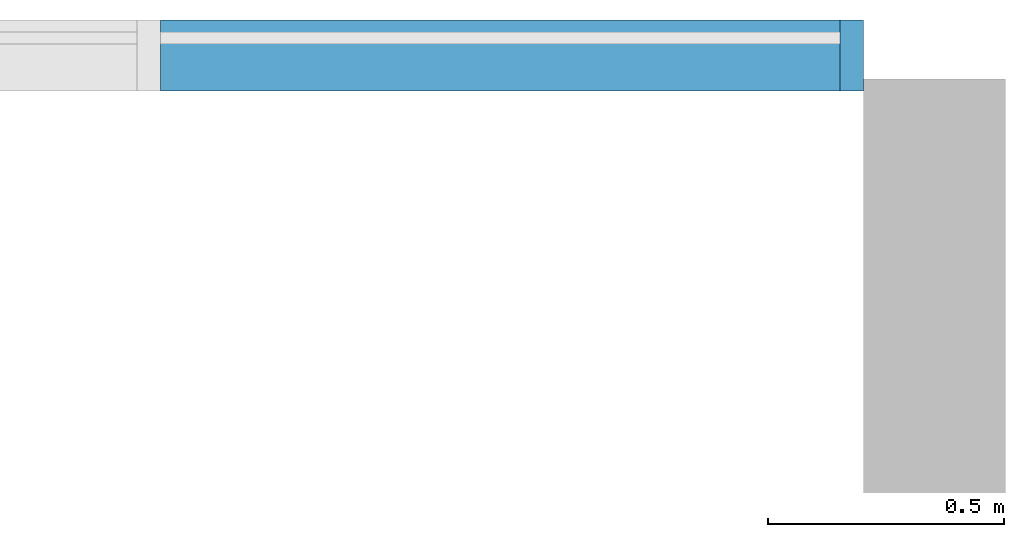
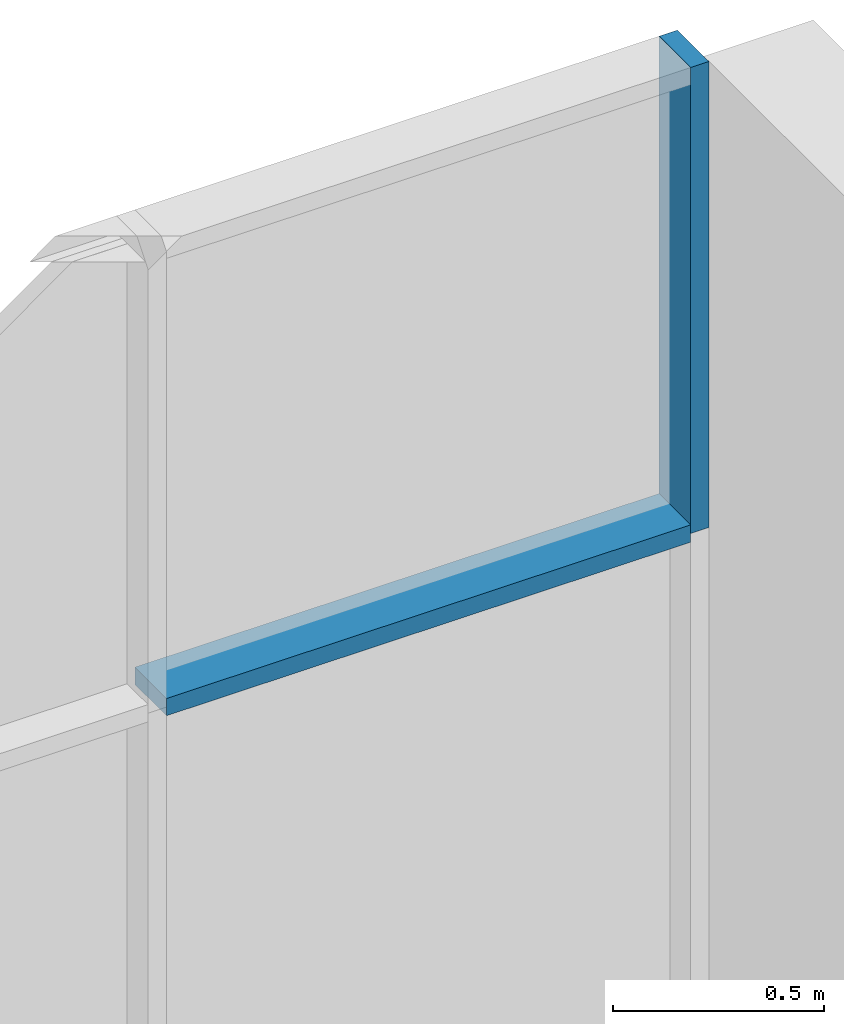
# One storey, part 5 of 13: 2 members, 1 element without a shape of its own.
"""IFC2X3 building model written with IfcOpenShell, lengths in millimetres."""

import ifcopenshell
import ifcopenshell.guid

model = None  # the IFC model being written
_history = None  # IfcOwnerHistory: only IFC2X3 demands one
_inside = {}  # id of a spatial element -> (the spatial element, [elements in it])
_under = {}  # id of a project, library or spatial element -> (it, [spatial elements below it])
_declared = {}  # id of a project -> (the project, [libraries it declares])
_typed = {}  # id of a type object -> (the type object, [elements of that type])
_made_of = {}  # id of a material, layer set ... -> (it, [elements and type objects made of it])


def new_model(schema):
    """Start an empty IFC model of exactly this schema.

    Asked for "IFC4X3", IfcOpenShell would pick the latest addendum, in which some entities
    have other attributes; the version numbers below select the first issue.
    IFC2X3 requires an IfcOwnerHistory on every rooted entity: one is made here for all.
    """
    global model, _history
    if schema == "IFC4X3":
        model = ifcopenshell.file(schema_version=(4, 3, 0, 0))
    else:
        model = ifcopenshell.file(schema=schema)
    _inside.clear()
    _under.clear()
    _declared.clear()
    _typed.clear()
    _made_of.clear()
    _history = None
    if model.schema == "IFC2X3":
        org = make("IfcOrganization", Name="unknown")
        user = make(
            "IfcPersonAndOrganization",
            ThePerson=make("IfcPerson", FamilyName="unknown"),
            TheOrganization=org,
        )
        app = make(
            "IfcApplication",
            ApplicationDeveloper=org,
            Version="unknown",
            ApplicationFullName="unknown",
            ApplicationIdentifier="unknown",
        )
        _history = make(
            "IfcOwnerHistory",
            OwningUser=user,
            OwningApplication=app,
            ChangeAction="ADDED",
            CreationDate=0,
        )
    return model


def make(cls, **values):
    """One entity of the class cls with the attributes given. An attribute that is None is left unset."""
    return model.create_entity(
        cls, **{name: value for name, value in values.items() if value is not None}
    )


def entity(cls, *values):
    """Any entity or typed value of the class cls, its attributes in the order of the schema. None: left unset."""
    e = model.create_entity(cls)
    for i, value in enumerate(values):
        if value is not None:
            e[i] = value
    return e


def rooted(cls, **values):
    """An entity with a GlobalId (a new one), such as an element, a storey or a relation."""
    return make(cls, GlobalId=ifcopenshell.guid.new(), OwnerHistory=_history, **values)


def si_unit(unit_type, name, prefix=None):
    """IfcSIUnit, for example si_unit("LENGTHUNIT", "METRE", prefix="MILLI")."""
    return make("IfcSIUnit", UnitType=unit_type, Prefix=prefix, Name=name)


def converted_unit(unit_type, name, factor, base, dimensions=None, offset=None):
    """IfcConversionBasedUnit, such as the inch: factor (a typed value) times the base unit."""
    return make(
        "IfcConversionBasedUnit"
        if offset is None
        else "IfcConversionBasedUnitWithOffset",
        ConversionOffset=offset,
        Dimensions=None
        if dimensions is None
        else entity("IfcDimensionalExponents", *dimensions),
        UnitType=unit_type,
        Name=name,
        ConversionFactor=make(
            "IfcMeasureWithUnit", ValueComponent=factor, UnitComponent=base
        ),
    )


def derived_unit(unit_type, elements):
    """IfcDerivedUnit: a product of units, each with its exponent."""
    return make(
        "IfcDerivedUnit",
        Elements=[
            make("IfcDerivedUnitElement", Unit=unit, Exponent=power)
            for unit, power in elements
        ],
        UnitType=unit_type,
    )


def assignment(units):
    """IfcUnitAssignment: the units of a project."""
    return None if units is None else make("IfcUnitAssignment", Units=units)


def point(xyz):
    """IfcCartesianPoint."""
    return None if xyz is None else make("IfcCartesianPoint", Coordinates=xyz)


def direction(xyz):
    """IfcDirection."""
    return None if xyz is None else make("IfcDirection", DirectionRatios=xyz)


def frame(location, z_axis=None, x_axis=None):
    """IfcAxis2Placement3D, a coordinate frame: its origin and axes. An axis left out is left unset."""
    return make(
        "IfcAxis2Placement3D",
        Location=point(location),
        Axis=direction(z_axis),
        RefDirection=direction(x_axis),
    )


def frame_2d(location, x_axis=None):
    """IfcAxis2Placement2D, a coordinate frame in the plane: its origin and x axis."""
    return make(
        "IfcAxis2Placement2D", Location=point(location), RefDirection=direction(x_axis)
    )


def origin():
    """The frame at (0, 0, 0) with its axes left unset."""
    return frame((0.0, 0.0, 0.0))


def origin_2d_with_axis():
    """The frame at (0, 0) in the plane with the x axis (1, 0) written out."""
    return frame_2d((0.0, 0.0), x_axis=(1.0, 0.0))


def place(relative_to, where):
    """IfcLocalPlacement: puts the frame where relative to a parent placement (None: the world)."""
    return make(
        "IfcLocalPlacement", PlacementRelTo=relative_to, RelativePlacement=where
    )


def context(
    kind, dimensions, precision=None, world=None, true_north=None, identifier=None
):
    """IfcGeometricRepresentationContext, for example the 3D "Model" context."""
    return make(
        "IfcGeometricRepresentationContext",
        ContextIdentifier=identifier,
        ContextType=kind,
        CoordinateSpaceDimension=dimensions,
        Precision=precision,
        WorldCoordinateSystem=world,
        TrueNorth=true_north,
    )


def subcontext(parent, identifier, kind, view, scale=None):
    """IfcGeometricRepresentationSubContext, for example "Body" below "Model"."""
    return make(
        "IfcGeometricRepresentationSubContext",
        ContextIdentifier=identifier,
        ContextType=kind,
        ParentContext=parent,
        TargetScale=scale,
        TargetView=view,
    )


def project(units=None, contexts=None):
    """IfcProject with its units and contexts."""
    return rooted(
        "IfcProject",
        Name="project",
        RepresentationContexts=contexts,
        UnitsInContext=assignment(units),
    )


def spatial(cls, under=None, at=None, **own):
    """A site, building, storey or space (cls), placed at a placement, below another one or the project."""
    s = rooted(cls, ObjectPlacement=at, **own)
    if under is not None:
        _under.setdefault(under.id(), (under, []))[1].append(s)
    return s


def profile(cls, at=None, kind="AREA", **sizes):
    """A parametric profile (cls). Its sizes go by their IFC names, for example OverallWidth=200.0."""
    return make(cls, ProfileType=kind, Position=at, **sizes)


def rectangle(**sizes):
    """IfcRectangleProfileDef."""
    return profile("IfcRectangleProfileDef", **sizes)


def extrude(swept, where, along, depth):
    """IfcExtrudedAreaSolid: the profile swept, set in the frame where, extruded along a direction by depth."""
    return make(
        "IfcExtrudedAreaSolid",
        SweptArea=swept,
        Position=where,
        ExtrudedDirection=direction(along),
        Depth=depth,
    )


def shape(context_of_items, identifier, shape_type, items):
    """IfcShapeRepresentation: the items that make up one representation, for example the "Body"."""
    return make(
        "IfcShapeRepresentation",
        ContextOfItems=context_of_items,
        RepresentationIdentifier=identifier,
        RepresentationType=shape_type,
        Items=items,
    )


def material(Name=None, Category=None):
    """IfcMaterial."""
    return make("IfcMaterial", Name=Name, Category=Category)


def made_of(thing, what):
    """Note that an element or type object is made of a material, layer set ...; save() writes the relation."""
    if what is not None:
        _made_of.setdefault(what.id(), (what, []))[1].append(thing)
    return thing


def type_object(cls, material=None, **own):
    """A type object (cls), such as IfcWallType, which elements share."""
    return made_of(rooted(cls, **own), material)


def element(
    cls,
    number,
    at=None,
    inside=None,
    cuts=None,
    type_object=None,
    material=None,
    context=None,
    identifier="Body",
    shape_type=None,
    held_by="IfcProductDefinitionShape",
    body=None,
    shapes=None,
    **own,
):
    """One element of the class cls, such as IfcWall. Its Tag is "e" and its number.

    at: its placement. inside: the storey or other place that contains it. cuts: it is an
    opening in that element (IfcRelVoidsElement). A single representation is given by context,
    identifier, shape_type and body (its items); several are given by shapes. held_by: the class
    of the entity that holds the representations. save() writes the other relations.
    """
    e = rooted(cls, Tag="e%d" % number, ObjectPlacement=at, **own)
    if body is not None:
        shapes = [shape(context, identifier, shape_type, body)]
    if shapes is not None:
        e.Representation = make(held_by, Representations=shapes)
    if inside is not None:
        _inside.setdefault(inside.id(), (inside, []))[1].append(e)
    if cuts is not None:
        rooted(
            "IfcRelVoidsElement", RelatingBuildingElement=cuts, RelatedOpeningElement=e
        )
    if type_object is not None:
        _typed.setdefault(type_object.id(), (type_object, []))[1].append(e)
    return made_of(e, material)


def aggregate(whole, parts):
    """IfcRelAggregates: a whole, such as a stair, and the parts it consists of."""
    return rooted("IfcRelAggregates", RelatingObject=whole, RelatedObjects=parts)


def save(model, path):
    """Write the relations noted so far, then the file.

    IfcRelAggregates (storeys below a building ...), IfcRelContainedInSpatialStructure (elements
    in a storey), IfcRelDefinesByType, IfcRelAssociatesMaterial and IfcRelDeclares: one each for
    every whole, place, type object, material and project.
    """
    for whole, parts in _under.values():
        aggregate(whole, parts)
    for where, things in _inside.values():
        rooted(
            "IfcRelContainedInSpatialStructure",
            RelatedElements=things,
            RelatingStructure=where,
        )
    for kind, things in _typed.values():
        rooted("IfcRelDefinesByType", RelatedObjects=things, RelatingType=kind)
    for what, things in _made_of.values():
        rooted("IfcRelAssociatesMaterial", RelatedObjects=things, RelatingMaterial=what)
    for by, libraries in _declared.values():
        rooted("IfcRelDeclares", RelatingContext=by, RelatedDefinitions=libraries)
    model.write(path)


model = new_model("IFC2X3")

# Units and contexts
model_context = context("Model", 3, precision=0.01, world=origin(), true_north=direction((6.12303176911189e-17, 1.0)))
context_of_model = context(None, 3, precision=0.01, world=origin(), true_north=direction((6.12303176911189e-17, 1.0)))
body_context = subcontext(model_context, "Body", "Model", "MODEL_VIEW")
ifc_project = project(units=[si_unit("LENGTHUNIT", "METRE", prefix="MILLI"), si_unit("AREAUNIT", "SQUARE_METRE"), si_unit("VOLUMEUNIT", "CUBIC_METRE"), converted_unit("PLANEANGLEUNIT", "DEGREE", entity("IfcRatioMeasure", 0.0174532925199433), si_unit("PLANEANGLEUNIT", "RADIAN"), dimensions=[0, 0, 0, 0, 0, 0, 0]), si_unit("MASSUNIT", "GRAM", prefix="KILO"), si_unit("TIMEUNIT", "SECOND"), si_unit("FREQUENCYUNIT", "HERTZ"), si_unit("THERMODYNAMICTEMPERATUREUNIT", "DEGREE_CELSIUS"), derived_unit("THERMALTRANSMITTANCEUNIT", [(si_unit("MASSUNIT", "GRAM", prefix="KILO"), 1), (si_unit("THERMODYNAMICTEMPERATUREUNIT", "KELVIN"), -1), (si_unit("TIMEUNIT", "SECOND"), -3)]), derived_unit("VOLUMETRICFLOWRATEUNIT", [(si_unit("LENGTHUNIT", "METRE"), 3), (si_unit("TIMEUNIT", "SECOND"), -1)]), si_unit("ELECTRICCURRENTUNIT", "AMPERE"), si_unit("ELECTRICVOLTAGEUNIT", "VOLT"), si_unit("POWERUNIT", "WATT"), si_unit("FORCEUNIT", "NEWTON", prefix="KILO"), si_unit("ILLUMINANCEUNIT", "LUX"), si_unit("LUMINOUSFLUXUNIT", "LUMEN"), si_unit("LUMINOUSINTENSITYUNIT", "CANDELA"), si_unit("PRESSUREUNIT", "PASCAL")], contexts=[model_context, context_of_model])

# Site, building, storey
site_placement = place(None, origin())
site = spatial("IfcSite", under=ifc_project, at=site_placement, CompositionType="ELEMENT")
building_placement = place(site_placement, origin())
building = spatial("IfcBuilding", under=site, at=building_placement, CompositionType="ELEMENT")
storey_placement = place(building_placement, frame((0.0, 0.0, 3750.0)))
storey = spatial("IfcBuildingStorey", under=building, at=storey_placement, Name="02. 2 etg.", CompositionType="ELEMENT", Elevation=3750.00000000068)

# Curtain wall, members
curtain_wall_type = type_object("IfcCurtainWallType", Name="Curtain Wall:Storefront", PredefinedType="NOTDEFINED")
curtain_wall_placement = place(storey_placement, frame((0.0, 0.0, -3750.0)))
curtain_wall = element("IfcCurtainWall", 1, at=curtain_wall_placement, inside=storey, type_object=curtain_wall_type, Name="Curtain Wall:Storefront", ObjectType="Curtain Wall:Storefront")
ifc_material = material(Name="Aluminium")
member_1_placement = place(curtain_wall_placement, frame((29449.1178561748, 18905.0, 6150.0)))
member_1 = element("IfcMember", 2, at=member_1_placement, material=ifc_material, Name="Curtain Wall:Storefront:8486", ObjectType="Curtain Wall:Storefront:8486", context=body_context, shape_type="SweptSolid", body=[
    extrude(rectangle(XDim=150.000000000001, YDim=50.0000000000016, at=origin_2d_with_axis()), frame((25.0, 75.0, 0.0), z_axis=(0.0, 0.0, 1.0), x_axis=(0.0, 1.0, 0.0)), (0.0, 0.0, 1.0), 1349.99999999993),
])
member_2_placement = place(curtain_wall_placement, frame((28012.4511895081, 18905.0, 6125.0)))
member_2 = element("IfcMember", 3, at=member_2_placement, material=ifc_material, Name="Curtain Wall:Storefront:8486", ObjectType="Curtain Wall:Storefront:8486", context=body_context, shape_type="SweptSolid", body=[
    extrude(rectangle(XDim=1436.66666666667, YDim=150.000000000001, at=frame_2d((0.0, 1.08713038571295e-12), x_axis=(1.0, 0.0))), frame((718.333333333335, 75.0, 0.0), z_axis=(0.0, 0.0, 1.0), x_axis=(-1.0, 0.0, 0.0)), (0.0, 0.0, 1.0), 49.9999999999995),
])
aggregate(curtain_wall, [member_1, member_2])

save(model, "model.ifc")
